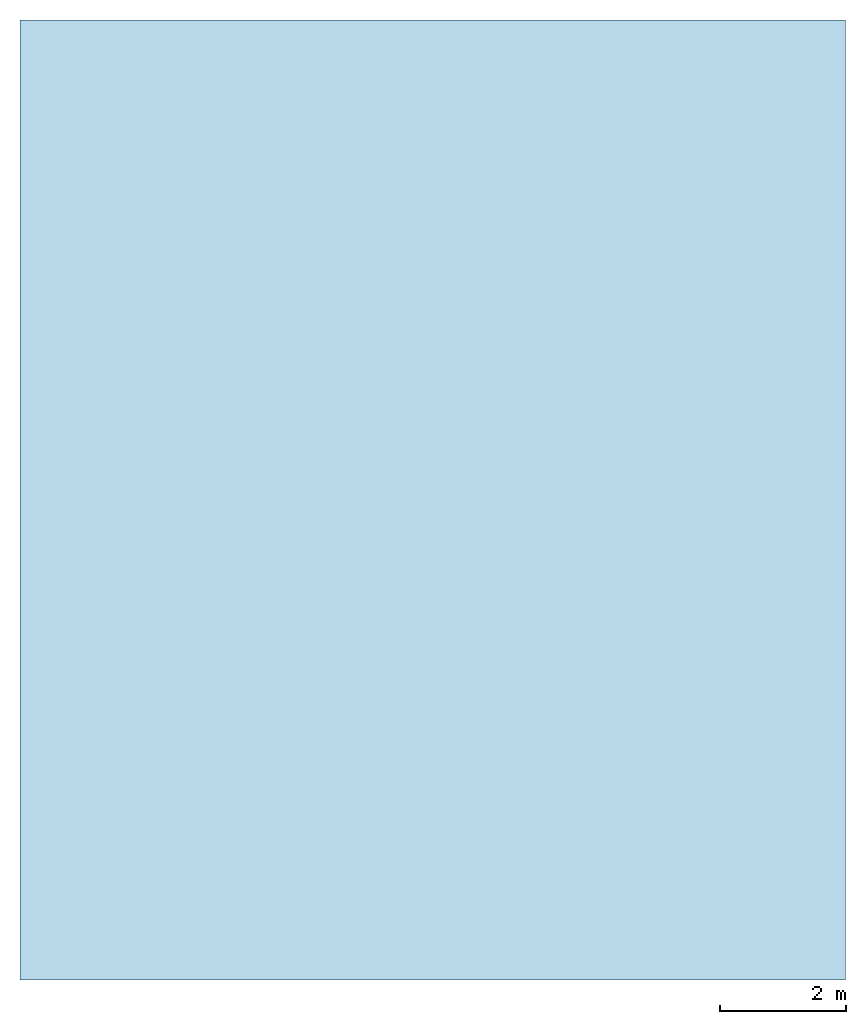
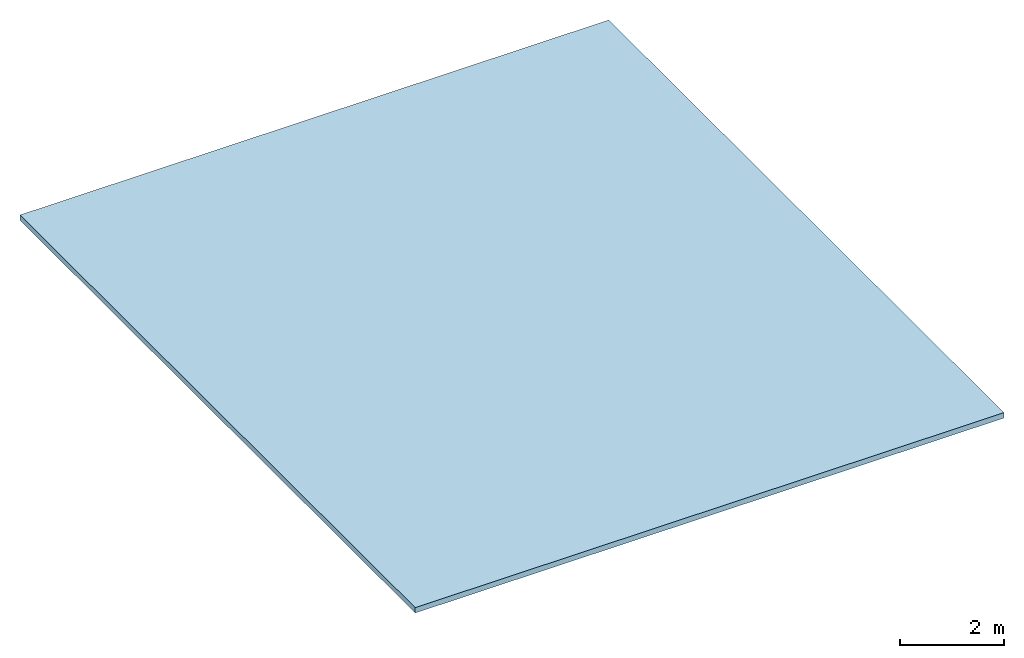
# One storey: 1 slab.
"""IFC2X3 building model written with IfcOpenShell, lengths in feet."""

from ifc_helpers import new_model, entity, si_unit, converted_unit, derived_unit, direction, frame, origin, origin_2d_with_axis, place, context, subcontext, project, spatial, rectangle, extrude, material, layer, layer_set, layer_usage, type_object, element, save


model = new_model("IFC2X3")

# Units and contexts
model_context = context("Model", 3, precision=0.0001, world=origin(), true_north=direction((6.123031769111886e-17, 1.0)))
body_context = subcontext(model_context, "Body", "Model", "MODEL_VIEW")
ifc_project = project(units=[converted_unit("LENGTHUNIT", "FOOT", entity("IfcLengthMeasure", 0.3048), si_unit("LENGTHUNIT", "METRE"), dimensions=[1, 0, 0, 0, 0, 0, 0]), converted_unit("AREAUNIT", "SQUARE FOOT", entity("IfcAreaMeasure", 0.09290304), si_unit("AREAUNIT", "SQUARE_METRE"), dimensions=[2, 0, 0, 0, 0, 0, 0]), converted_unit("VOLUMEUNIT", "CUBIC FOOT", entity("IfcVolumeMeasure", 0.028316846592000004), si_unit("VOLUMEUNIT", "CUBIC_METRE"), dimensions=[3, 0, 0, 0, 0, 0, 0]), converted_unit("PLANEANGLEUNIT", "DEGREE", entity("IfcPlaneAngleMeasure", 0.017453292519943278), si_unit("PLANEANGLEUNIT", "RADIAN"), dimensions=[0, 0, 0, 0, 0, 0, 0]), si_unit("MASSUNIT", "GRAM", prefix="KILO"), derived_unit("MASSDENSITYUNIT", [(si_unit("MASSUNIT", "GRAM", prefix="KILO"), 1), (si_unit("LENGTHUNIT", "METRE"), -3)]), derived_unit("IONCONCENTRATIONUNIT", [(si_unit("MASSUNIT", "GRAM", prefix="KILO"), 1), (si_unit("LENGTHUNIT", "METRE"), -3)]), derived_unit("MOMENTOFINERTIAUNIT", [(si_unit("LENGTHUNIT", "METRE"), 4)]), si_unit("TIMEUNIT", "SECOND"), si_unit("FREQUENCYUNIT", "HERTZ"), si_unit("THERMODYNAMICTEMPERATUREUNIT", "DEGREE_CELSIUS"), derived_unit("THERMALTRANSMITTANCEUNIT", [(si_unit("MASSUNIT", "GRAM", prefix="KILO"), 1), (si_unit("THERMODYNAMICTEMPERATUREUNIT", "KELVIN"), -1), (si_unit("TIMEUNIT", "SECOND"), -3)]), derived_unit("THERMALCONDUCTANCEUNIT", [(si_unit("MASSUNIT", "GRAM", prefix="KILO"), 1), (si_unit("THERMODYNAMICTEMPERATUREUNIT", "KELVIN"), -1), (si_unit("TIMEUNIT", "SECOND"), -3), (si_unit("LENGTHUNIT", "METRE"), 1)]), derived_unit("VOLUMETRICFLOWRATEUNIT", [(si_unit("LENGTHUNIT", "METRE"), 3), (si_unit("TIMEUNIT", "SECOND"), -1)]), derived_unit("MASSFLOWRATEUNIT", [(si_unit("MASSUNIT", "GRAM", prefix="KILO"), 1), (si_unit("TIMEUNIT", "SECOND"), -1)]), derived_unit("ROTATIONALFREQUENCYUNIT", [(si_unit("TIMEUNIT", "SECOND"), -1)]), si_unit("ELECTRICCURRENTUNIT", "AMPERE"), si_unit("ELECTRICVOLTAGEUNIT", "VOLT"), si_unit("POWERUNIT", "WATT"), converted_unit("FORCEUNIT", "KIP", entity("IfcForceMeasure", 2.088543423315013e-05), si_unit("FORCEUNIT", "NEWTON"), dimensions=[1, 1, -2, 0, 0, 0, 0]), si_unit("ILLUMINANCEUNIT", "LUX"), si_unit("LUMINOUSFLUXUNIT", "LUMEN"), si_unit("LUMINOUSINTENSITYUNIT", "CANDELA"), si_unit("ENERGYUNIT", "JOULE"), derived_unit("USERDEFINED", [(si_unit("MASSUNIT", "GRAM", prefix="KILO"), -1), (si_unit("LENGTHUNIT", "METRE"), -2), (si_unit("TIMEUNIT", "SECOND"), 3), (si_unit("LUMINOUSFLUXUNIT", "LUMEN"), 1)]), derived_unit("USERDEFINED", [(si_unit("MASSUNIT", "GRAM", prefix="KILO"), 1), (si_unit("TIMEUNIT", "SECOND"), -3), (si_unit("LENGTHUNIT", "METRE"), 3), (si_unit("ELECTRICCURRENTUNIT", "AMPERE"), -2)]), derived_unit("SOUNDPOWERUNIT", [(si_unit("MASSUNIT", "GRAM", prefix="KILO"), 1), (si_unit("TIMEUNIT", "SECOND"), -3), (si_unit("LENGTHUNIT", "METRE"), 2)]), derived_unit("SOUNDPRESSUREUNIT", [(si_unit("MASSUNIT", "GRAM", prefix="KILO"), 1), (si_unit("LENGTHUNIT", "METRE"), -1), (si_unit("TIMEUNIT", "SECOND"), -2)]), derived_unit("LINEARVELOCITYUNIT", [(si_unit("LENGTHUNIT", "METRE"), 1), (si_unit("TIMEUNIT", "SECOND"), -1)]), si_unit("PRESSUREUNIT", "PASCAL"), derived_unit("USERDEFINED", [(si_unit("MASSUNIT", "GRAM", prefix="KILO"), 1), (si_unit("LENGTHUNIT", "METRE"), -2), (si_unit("TIMEUNIT", "SECOND"), -2)]), derived_unit("LINEARFORCEUNIT", [(si_unit("MASSUNIT", "GRAM", prefix="KILO"), 1), (si_unit("TIMEUNIT", "SECOND"), -2)]), derived_unit("PLANARFORCEUNIT", [(si_unit("MASSUNIT", "GRAM", prefix="KILO"), 1), (si_unit("LENGTHUNIT", "METRE"), -1), (si_unit("TIMEUNIT", "SECOND"), -2)]), derived_unit("SPECIFICHEATCAPACITYUNIT", [(si_unit("THERMODYNAMICTEMPERATUREUNIT", "KELVIN"), -1), (si_unit("LENGTHUNIT", "METRE"), 2), (si_unit("TIMEUNIT", "SECOND"), -2)]), derived_unit("HEATFLUXDENSITYUNIT", [(si_unit("MASSUNIT", "GRAM", prefix="KILO"), 1), (si_unit("TIMEUNIT", "SECOND"), -3)]), derived_unit("HEATINGVALUEUNIT", [(si_unit("LENGTHUNIT", "METRE"), 2), (si_unit("TIMEUNIT", "SECOND"), -2)]), derived_unit("VAPORPERMEABILITYUNIT", [(si_unit("LENGTHUNIT", "METRE"), -1), (si_unit("TIMEUNIT", "SECOND"), 1)]), derived_unit("DYNAMICVISCOSITYUNIT", [(si_unit("MASSUNIT", "GRAM", prefix="KILO"), 1), (si_unit("TIMEUNIT", "SECOND"), -1), (si_unit("LENGTHUNIT", "METRE"), -1)]), derived_unit("THERMALEXPANSIONCOEFFICIENTUNIT", [(si_unit("THERMODYNAMICTEMPERATUREUNIT", "KELVIN"), -1)]), derived_unit("MODULUSOFELASTICITYUNIT", [(si_unit("MASSUNIT", "GRAM", prefix="KILO"), 1), (si_unit("LENGTHUNIT", "METRE"), -1), (si_unit("TIMEUNIT", "SECOND"), -2)]), derived_unit("ISOTHERMALMOISTURECAPACITYUNIT", [(si_unit("LENGTHUNIT", "METRE"), 3), (si_unit("MASSUNIT", "GRAM", prefix="KILO"), -1)]), derived_unit("MOISTUREDIFFUSIVITYUNIT", [(si_unit("TIMEUNIT", "SECOND"), -1), (si_unit("LENGTHUNIT", "METRE"), 2)]), derived_unit("MASSPERLENGTHUNIT", [(si_unit("MASSUNIT", "GRAM", prefix="KILO"), 1), (si_unit("LENGTHUNIT", "METRE"), -1)]), derived_unit("THERMALRESISTANCEUNIT", [(si_unit("MASSUNIT", "GRAM", prefix="KILO"), -1), (si_unit("TIMEUNIT", "SECOND"), 3), (si_unit("THERMODYNAMICTEMPERATUREUNIT", "KELVIN"), 1)]), derived_unit("ACCELERATIONUNIT", [(si_unit("LENGTHUNIT", "METRE"), 1), (si_unit("TIMEUNIT", "SECOND"), -2)]), derived_unit("ANGULARVELOCITYUNIT", [(si_unit("TIMEUNIT", "SECOND"), -1), (si_unit("PLANEANGLEUNIT", "RADIAN"), 1)]), derived_unit("LINEARSTIFFNESSUNIT", [(si_unit("MASSUNIT", "GRAM", prefix="KILO"), 1), (si_unit("TIMEUNIT", "SECOND"), -2)]), derived_unit("WARPINGCONSTANTUNIT", [(si_unit("LENGTHUNIT", "METRE"), 6)]), derived_unit("LINEARMOMENTUNIT", [(si_unit("MASSUNIT", "GRAM", prefix="KILO"), 1), (si_unit("LENGTHUNIT", "METRE"), 1), (si_unit("TIMEUNIT", "SECOND"), -2)]), derived_unit("TORQUEUNIT", [(si_unit("MASSUNIT", "GRAM", prefix="KILO"), 1), (si_unit("LENGTHUNIT", "METRE"), 2), (si_unit("TIMEUNIT", "SECOND"), -2)])], contexts=[model_context])

# Site, building, storey
site_placement = place(None, origin())
site = spatial("IfcSite", under=ifc_project, at=site_placement, CompositionType="ELEMENT")
building_placement = place(site_placement, origin())
building = spatial("IfcBuilding", under=site, at=building_placement, CompositionType="ELEMENT")
storey_placement = place(building_placement, frame((0.0, 0.0, 28.25000000000186)))
storey = spatial("IfcBuildingStorey", under=building, at=storey_placement, Name="Third Floor", CompositionType="ELEMENT", Elevation=28.25000000000186)

# Slab
ifc_material = material(Name="Default Floor")
ifc_layer = layer(ifc_material, 0.4166666666666667)
ifc_layer_set = layer_set([ifc_layer])
ifc_layer_usage = layer_usage(ifc_layer_set, "AXIS3", "POSITIVE", 0.0)
slab_type = type_object("IfcSlabType", PredefinedType="FLOOR", material=ifc_layer_set)
slab_placement = place(storey_placement, origin())
element("IfcSlab", 1, at=slab_placement, inside=storey, type_object=slab_type, material=ifc_layer_usage, PredefinedType="FLOOR", context=body_context, shape_type="SweptSolid", body=[
    extrude(rectangle(XDim=50.00000000000018, YDim=42.99999999999993, at=origin_2d_with_axis()), frame((28.874478019162204, -27.34124484724897, 0.0), z_axis=(0.0, 0.0, -1.0), x_axis=(0.0, 1.0, 0.0)), (0.0, 0.0, 1.0), 0.41666666666666785),
])

save(model, "model.ifc")
